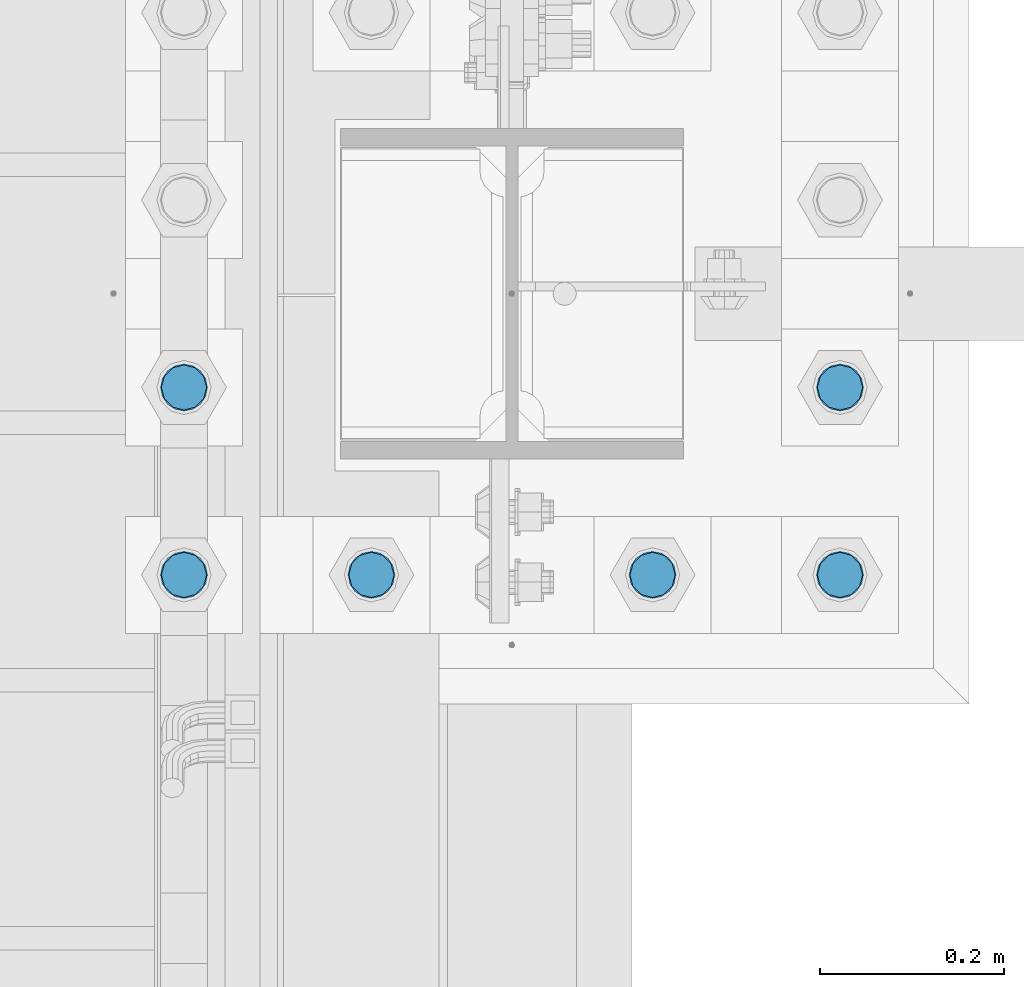
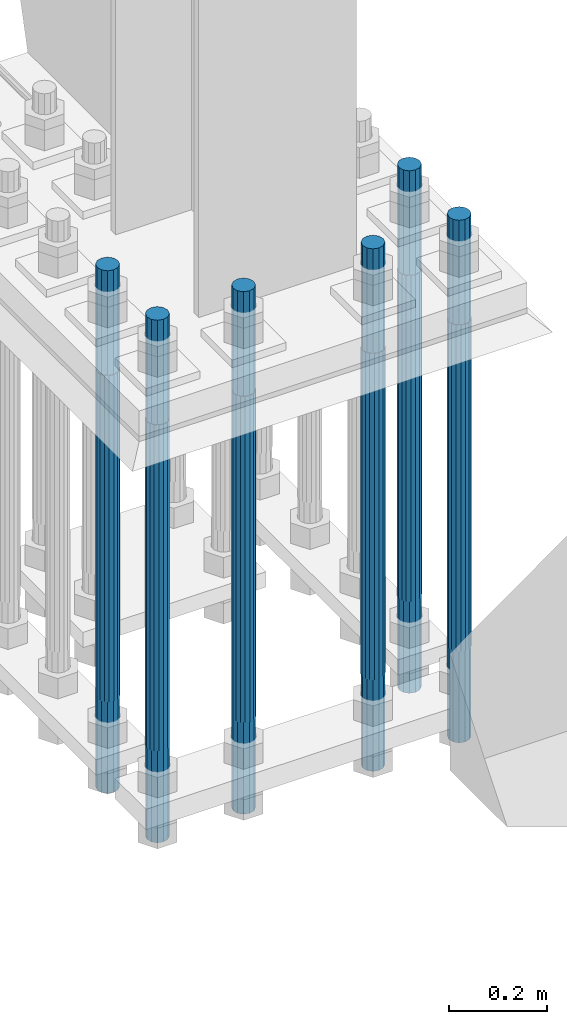
# One storey, part 1295 of 3843: 6 columns, 1 element without a shape of its own.
"""IFC2X3 building model written with IfcOpenShell, lengths in millimetres."""

from ifc_helpers import new_model, si_unit, frame, origin_with_axes, place, context, subcontext, project, spatial, faceted_brep, material, type_object, element, aggregate, save


model = new_model("IFC2X3")

# Units and contexts
model_context = context("Model", 3, precision=1e-05, world=origin_with_axes())
body_context = subcontext(model_context, "Body", "Model", "MODEL_VIEW")
ifc_project = project(units=[si_unit("LENGTHUNIT", "METRE", prefix="MILLI"), si_unit("AREAUNIT", "SQUARE_METRE"), si_unit("VOLUMEUNIT", "CUBIC_METRE"), si_unit("MASSUNIT", "GRAM", prefix="KILO"), si_unit("TIMEUNIT", "SECOND"), si_unit("PLANEANGLEUNIT", "RADIAN"), si_unit("SOLIDANGLEUNIT", "STERADIAN"), si_unit("THERMODYNAMICTEMPERATUREUNIT", "DEGREE_CELSIUS"), si_unit("LUMINOUSINTENSITYUNIT", "LUMEN")], contexts=[model_context])

# Site, building, storey
site_placement = place(None, origin_with_axes())
site = spatial("IfcSite", under=ifc_project, at=site_placement, CompositionType="ELEMENT")
building_placement = place(site_placement, origin_with_axes())
building = spatial("IfcBuilding", under=site, at=building_placement, Name="Undefined", CompositionType="ELEMENT")
storey_placement = place(building_placement, origin_with_axes())
storey = spatial("IfcBuildingStorey", under=building, at=storey_placement, Name="Undefined", CompositionType="ELEMENT", Elevation=0.0)

# Assembly, columns
assembly_placement = place(storey_placement, origin_with_axes())
assembly = element("IfcElementAssembly", 1, at=assembly_placement, inside=storey, Name="TEMPLATE", AssemblyPlace="NOTDEFINED", PredefinedType="RIGID_FRAME")
ifc_material = material(Name="Undefined/F1554-GR.55")
column_type = type_object("IfcColumnType", PredefinedType="NOTDEFINED")
column_1_placement = place(assembly_placement, frame((55575.2, 20002.5, 29565.6), z_axis=(0.0, -1.0, 0.0), x_axis=(0.0, 0.0, -1.0)))
column_1 = element("IfcColumn", 2, at=column_1_placement, type_object=column_type, material=ifc_material, Name="ANCHOR_ROD", context=body_context, shape_type="Brep", body=[
    faceted_brep([(-260.349999999999, -21.2176223927163, 12.25), (-260.349999999999, -12.25, 21.2176223927199), (-260.349999999999, 0.0, 24.5), (-260.349999999999, 12.25, 21.2176223927199), (-260.349999999999, 21.2176223927163, 12.25), (-260.349999999999, 24.5, 0.0), (-260.349999999999, 21.2176223927163, -12.25), (-260.349999999999, 12.25, -21.2176223927199), (-260.349999999999, 0.0, -24.5), (-260.349999999999, -12.25, -21.2176223927199), (-260.349999999999, -21.2176223927163, -12.25), (-260.349999999999, -24.5, 0.0), (0.0, 24.5000000000146, 0.0), (0.0, 21.2176223927381, -12.25), (0.0, 12.2500000000146, -21.2176223927163), (0.0, 1.45519152283669e-11, -24.5), (0.0, -12.2499999999854, -21.2176223927163), (0.0, -21.217622392709, -12.25), (0.0, -24.4999999999854, 0.0), (0.0, -21.217622392709, 12.25), (0.0, -12.2499999999854, 21.2176223927163), (0.0, 1.45519152283669e-11, 24.5), (0.0, 12.2500000000146, 21.2176223927163), (0.0, 21.2176223927381, 12.25), (0.0, -23.4665401257807, 9.72015918207035), (0.0, -17.9605122421344, 17.9605122421417), (0.0, -9.72015918207762, 23.466540125788), (0.0, 0.0, 25.4000000000015), (0.0, 9.72015918207762, 23.466540125788), (0.0, 17.9605122421344, 17.9605122421417), (0.0, 23.4665401257807, 9.72015918207035), (0.0, 25.3999996185303, 0.0), (0.0, 23.4665401257807, -9.72015918207035), (0.0, 17.9605122421344, -17.9605122421417), (0.0, 9.72015918207762, -23.466540125788), (0.0, 0.0, -25.4000000000015), (0.0, -9.72015918207762, -23.466540125788), (0.0, -17.9605122421344, -17.9605122421417), (0.0, -23.4665401257807, -9.72015918207035), (0.0, -25.3999996185303, 0.0), (812.799999999999, -25.4000000000015, 0.0), (812.799999999999, -23.466540125788, 9.72015918207398), (812.799999999999, -17.9605122421417, 17.9605122421381), (812.799999999999, -9.72015918207035, 23.466540125788), (812.799999999999, 0.0, 25.4000000000015), (812.799999999999, 9.72015918207035, 23.466540125788), (812.799999999999, 17.9605122421417, 17.9605122421381), (812.799999999999, 23.466540125788, 9.72015918207398), (812.799999999999, 25.4000000000015, 0.0), (812.799999999999, 23.466540125788, -9.72015918207398), (812.799999999999, 17.9605122421417, -17.9605122421381), (812.799999999999, 9.72015918207035, -23.466540125788), (812.799999999999, 0.0, -25.4000000000015), (812.799999999999, -9.72015918207035, -23.466540125788), (812.799999999999, -17.9605122421417, -17.9605122421381), (812.799999999999, -23.466540125788, -9.72015918207398), (812.799999999999, -12.25, 21.2176223927199), (812.799999999999, 0.0, 24.5), (812.799999999999, 12.25, 21.2176223927199), (812.799999999999, 21.2176223927163, 12.25), (812.799999999999, 24.5, 0.0), (812.799999999999, 21.2176223927163, -12.25), (812.799999999999, 12.25, -21.2176223927199), (812.799999999999, 0.0, -24.5), (812.799999999999, -12.25, -21.2176223927199), (812.799999999999, -21.2176223927163, -12.25), (812.799999999999, -24.5, 0.0), (812.799999999999, -21.2176223927163, 12.25), (1041.4, -12.25, -21.2176223927199), (1041.4, 0.0, -24.5), (1041.4, 12.25, -21.2176223927199), (1041.4, 21.2176223927163, -12.25), (1041.4, 24.5, 0.0), (1041.4, 21.2176223927163, 12.25), (1041.4, 12.25, 21.2176223927199), (1041.4, 0.0, 24.5), (1041.4, -12.25, 21.2176223927199), (1041.4, -21.2176223927163, 12.25), (1041.4, -24.5, 0.0), (1041.4, -21.2176223927163, -12.25)], [[[0, 1, 2, 3, 4, 5, 6, 7, 8, 9, 10, 11]], [[6, 5, 12, 13]], [[7, 6, 13, 14]], [[8, 7, 14, 15]], [[9, 8, 15, 16]], [[10, 9, 16, 17]], [[11, 10, 17, 18]], [[0, 11, 18, 19]], [[1, 0, 19, 20]], [[2, 1, 20, 21]], [[3, 2, 21, 22]], [[4, 3, 22, 23]], [[5, 4, 23, 12]], [[24, 25, 26, 27, 28, 29, 30, 31, 32, 33, 34, 35, 36, 37, 38, 39], [22, 21, 20, 19, 18, 17, 16, 15, 14, 13, 12, 23]], [[24, 39, 40, 41]], [[25, 24, 41, 42]], [[26, 25, 42, 43]], [[27, 26, 43, 44]], [[28, 27, 44, 45]], [[29, 28, 45, 46]], [[30, 29, 46, 47]], [[31, 30, 47, 48]], [[32, 31, 48, 49]], [[33, 32, 49, 50]], [[34, 33, 50, 51]], [[35, 34, 51, 52]], [[36, 35, 52, 53]], [[37, 36, 53, 54]], [[38, 37, 54, 55]], [[39, 38, 55, 40]], [[54, 53, 52, 51, 50, 49, 48, 47, 46, 45, 44, 43, 42, 41, 40, 55], [56, 57, 58, 59, 60, 61, 62, 63, 64, 65, 66, 67]], [[68, 69, 70, 71, 72, 73, 74, 75, 76, 77, 78, 79]], [[76, 75, 57, 56]], [[77, 76, 56, 67]], [[78, 77, 67, 66]], [[79, 78, 66, 65]], [[68, 79, 65, 64]], [[69, 68, 64, 63]], [[70, 69, 63, 62]], [[71, 70, 62, 61]], [[72, 71, 61, 60]], [[73, 72, 60, 59]], [[74, 73, 59, 58]], [[75, 74, 58, 57]]]),
])
column_2_placement = place(assembly_placement, frame((55778.4, 20002.5, 29565.6), z_axis=(0.0, -1.0, 0.0), x_axis=(0.0, 0.0, -1.0)))
column_2 = element("IfcColumn", 3, at=column_2_placement, type_object=column_type, material=ifc_material, Name="ANCHOR_ROD", context=body_context, shape_type="Brep", body=[
    faceted_brep([(-260.349999999999, -21.2176223927163, 12.25), (-260.349999999999, -12.25, 21.2176223927199), (-260.349999999999, 0.0, 24.5), (-260.349999999999, 12.25, 21.2176223927199), (-260.349999999999, 21.2176223927163, 12.25), (-260.349999999999, 24.5, 0.0), (-260.349999999999, 21.2176223927163, -12.25), (-260.349999999999, 12.25, -21.2176223927199), (-260.349999999999, 0.0, -24.5), (-260.349999999999, -12.25, -21.2176223927199), (-260.349999999999, -21.2176223927163, -12.25), (-260.349999999999, -24.5, 0.0), (0.0, 24.5000000000146, 0.0), (0.0, 21.2176223927381, -12.25), (0.0, 12.2500000000146, -21.2176223927163), (0.0, 1.45519152283669e-11, -24.5), (0.0, -12.2499999999854, -21.2176223927163), (0.0, -21.217622392709, -12.25), (0.0, -24.4999999999854, 0.0), (0.0, -21.217622392709, 12.25), (0.0, -12.2499999999854, 21.2176223927163), (0.0, 1.45519152283669e-11, 24.5), (0.0, 12.2500000000146, 21.2176223927163), (0.0, 21.2176223927381, 12.25), (0.0, -23.4665401257807, 9.72015918207035), (0.0, -17.9605122421344, 17.9605122421417), (0.0, -9.72015918207762, 23.466540125788), (0.0, 0.0, 25.4000000000015), (0.0, 9.72015918207762, 23.466540125788), (0.0, 17.9605122421344, 17.9605122421417), (0.0, 23.4665401257807, 9.72015918207035), (0.0, 25.3999996185303, 0.0), (0.0, 23.4665401257807, -9.72015918207035), (0.0, 17.9605122421344, -17.9605122421417), (0.0, 9.72015918207762, -23.466540125788), (0.0, 0.0, -25.4000000000015), (0.0, -9.72015918207762, -23.466540125788), (0.0, -17.9605122421344, -17.9605122421417), (0.0, -23.4665401257807, -9.72015918207035), (0.0, -25.3999996185303, 0.0), (812.799999999999, -25.4000000000015, 0.0), (812.799999999999, -23.466540125788, 9.72015918207398), (812.799999999999, -17.9605122421417, 17.9605122421381), (812.799999999999, -9.72015918207035, 23.466540125788), (812.799999999999, 0.0, 25.4000000000015), (812.799999999999, 9.72015918207035, 23.466540125788), (812.799999999999, 17.9605122421417, 17.9605122421381), (812.799999999999, 23.466540125788, 9.72015918207398), (812.799999999999, 25.4000000000015, 0.0), (812.799999999999, 23.466540125788, -9.72015918207398), (812.799999999999, 17.9605122421417, -17.9605122421381), (812.799999999999, 9.72015918207035, -23.466540125788), (812.799999999999, 0.0, -25.4000000000015), (812.799999999999, -9.72015918207035, -23.466540125788), (812.799999999999, -17.9605122421417, -17.9605122421381), (812.799999999999, -23.466540125788, -9.72015918207398), (812.799999999999, -12.25, 21.2176223927199), (812.799999999999, 0.0, 24.5), (812.799999999999, 12.25, 21.2176223927199), (812.799999999999, 21.2176223927163, 12.25), (812.799999999999, 24.5, 0.0), (812.799999999999, 21.2176223927163, -12.25), (812.799999999999, 12.25, -21.2176223927199), (812.799999999999, 0.0, -24.5), (812.799999999999, -12.25, -21.2176223927199), (812.799999999999, -21.2176223927163, -12.25), (812.799999999999, -24.5, 0.0), (812.799999999999, -21.2176223927163, 12.25), (1041.4, -12.25, -21.2176223927199), (1041.4, 0.0, -24.5), (1041.4, 12.25, -21.2176223927199), (1041.4, 21.2176223927163, -12.25), (1041.4, 24.5, 0.0), (1041.4, 21.2176223927163, 12.25), (1041.4, 12.25, 21.2176223927199), (1041.4, 0.0, 24.5), (1041.4, -12.25, 21.2176223927199), (1041.4, -21.2176223927163, 12.25), (1041.4, -24.5, 0.0), (1041.4, -21.2176223927163, -12.25)], [[[0, 1, 2, 3, 4, 5, 6, 7, 8, 9, 10, 11]], [[6, 5, 12, 13]], [[7, 6, 13, 14]], [[8, 7, 14, 15]], [[9, 8, 15, 16]], [[10, 9, 16, 17]], [[11, 10, 17, 18]], [[0, 11, 18, 19]], [[1, 0, 19, 20]], [[2, 1, 20, 21]], [[3, 2, 21, 22]], [[4, 3, 22, 23]], [[5, 4, 23, 12]], [[24, 25, 26, 27, 28, 29, 30, 31, 32, 33, 34, 35, 36, 37, 38, 39], [22, 21, 20, 19, 18, 17, 16, 15, 14, 13, 12, 23]], [[24, 39, 40, 41]], [[25, 24, 41, 42]], [[26, 25, 42, 43]], [[27, 26, 43, 44]], [[28, 27, 44, 45]], [[29, 28, 45, 46]], [[30, 29, 46, 47]], [[31, 30, 47, 48]], [[32, 31, 48, 49]], [[33, 32, 49, 50]], [[34, 33, 50, 51]], [[35, 34, 51, 52]], [[36, 35, 52, 53]], [[37, 36, 53, 54]], [[38, 37, 54, 55]], [[39, 38, 55, 40]], [[54, 53, 52, 51, 50, 49, 48, 47, 46, 45, 44, 43, 42, 41, 40, 55], [56, 57, 58, 59, 60, 61, 62, 63, 64, 65, 66, 67]], [[68, 69, 70, 71, 72, 73, 74, 75, 76, 77, 78, 79]], [[76, 75, 57, 56]], [[77, 76, 56, 67]], [[78, 77, 67, 66]], [[79, 78, 66, 65]], [[68, 79, 65, 64]], [[69, 68, 64, 63]], [[70, 69, 63, 62]], [[71, 70, 62, 61]], [[72, 71, 61, 60]], [[73, 72, 60, 59]], [[74, 73, 59, 58]], [[75, 74, 58, 57]]]),
])
column_3_placement = place(assembly_placement, frame((56083.2, 20002.5, 29565.6), z_axis=(0.0, 1.0, 0.0), x_axis=(0.0, 0.0, -1.0)))
column_3 = element("IfcColumn", 4, at=column_3_placement, type_object=column_type, material=ifc_material, Name="ANCHOR_ROD", context=body_context, shape_type="Brep", body=[
    faceted_brep([(-260.349999999999, -21.2176223927163, 12.25), (-260.349999999999, -12.25, 21.2176223927199), (-260.349999999999, 0.0, 24.5), (-260.349999999999, 12.25, 21.2176223927199), (-260.349999999999, 21.2176223927163, 12.25), (-260.349999999999, 24.5, 0.0), (-260.349999999999, 21.2176223927163, -12.25), (-260.349999999999, 12.25, -21.2176223927199), (-260.349999999999, 0.0, -24.5), (-260.349999999999, -12.25, -21.2176223927199), (-260.349999999999, -21.2176223927163, -12.25), (-260.349999999999, -24.5, 0.0), (0.0, 24.5000000000146, 0.0), (0.0, 21.2176223927381, -12.25), (0.0, 12.2500000000146, -21.2176223927163), (0.0, 1.45519152283669e-11, -24.5), (0.0, -12.2499999999854, -21.2176223927163), (0.0, -21.217622392709, -12.25), (0.0, -24.4999999999854, 0.0), (0.0, -21.217622392709, 12.25), (0.0, -12.2499999999854, 21.2176223927163), (0.0, 1.45519152283669e-11, 24.5), (0.0, 12.2500000000146, 21.2176223927163), (0.0, 21.2176223927381, 12.25), (0.0, -23.4665401257807, 9.72015918207035), (0.0, -17.9605122421344, 17.9605122421417), (0.0, -9.72015918207762, 23.466540125788), (0.0, 0.0, 25.4000000000015), (0.0, 9.72015918207762, 23.466540125788), (0.0, 17.9605122421344, 17.9605122421417), (0.0, 23.4665401257807, 9.72015918207035), (0.0, 25.3999996185303, 0.0), (0.0, 23.4665401257807, -9.72015918207035), (0.0, 17.9605122421344, -17.9605122421417), (0.0, 9.72015918207762, -23.466540125788), (0.0, 0.0, -25.4000000000015), (0.0, -9.72015918207762, -23.466540125788), (0.0, -17.9605122421344, -17.9605122421417), (0.0, -23.4665401257807, -9.72015918207035), (0.0, -25.3999996185303, 0.0), (812.799999999999, -25.4000000000015, 0.0), (812.799999999999, -23.466540125788, 9.72015918207398), (812.799999999999, -17.9605122421417, 17.9605122421381), (812.799999999999, -9.72015918207035, 23.466540125788), (812.799999999999, 0.0, 25.4000000000015), (812.799999999999, 9.72015918207035, 23.466540125788), (812.799999999999, 17.9605122421417, 17.9605122421381), (812.799999999999, 23.466540125788, 9.72015918207398), (812.799999999999, 25.4000000000015, 0.0), (812.799999999999, 23.466540125788, -9.72015918207398), (812.799999999999, 17.9605122421417, -17.9605122421381), (812.799999999999, 9.72015918207035, -23.466540125788), (812.799999999999, 0.0, -25.4000000000015), (812.799999999999, -9.72015918207035, -23.466540125788), (812.799999999999, -17.9605122421417, -17.9605122421381), (812.799999999999, -23.466540125788, -9.72015918207398), (812.799999999999, -12.25, 21.2176223927199), (812.799999999999, 0.0, 24.5), (812.799999999999, 12.25, 21.2176223927199), (812.799999999999, 21.2176223927163, 12.25), (812.799999999999, 24.5, 0.0), (812.799999999999, 21.2176223927163, -12.25), (812.799999999999, 12.25, -21.2176223927199), (812.799999999999, 0.0, -24.5), (812.799999999999, -12.25, -21.2176223927199), (812.799999999999, -21.2176223927163, -12.25), (812.799999999999, -24.5, 0.0), (812.799999999999, -21.2176223927163, 12.25), (1041.4, -12.25, -21.2176223927199), (1041.4, 0.0, -24.5), (1041.4, 12.25, -21.2176223927199), (1041.4, 21.2176223927163, -12.25), (1041.4, 24.5, 0.0), (1041.4, 21.2176223927163, 12.25), (1041.4, 12.25, 21.2176223927199), (1041.4, 0.0, 24.5), (1041.4, -12.25, 21.2176223927199), (1041.4, -21.2176223927163, 12.25), (1041.4, -24.5, 0.0), (1041.4, -21.2176223927163, -12.25)], [[[0, 1, 2, 3, 4, 5, 6, 7, 8, 9, 10, 11]], [[6, 5, 12, 13]], [[7, 6, 13, 14]], [[8, 7, 14, 15]], [[9, 8, 15, 16]], [[10, 9, 16, 17]], [[11, 10, 17, 18]], [[0, 11, 18, 19]], [[1, 0, 19, 20]], [[2, 1, 20, 21]], [[3, 2, 21, 22]], [[4, 3, 22, 23]], [[5, 4, 23, 12]], [[24, 25, 26, 27, 28, 29, 30, 31, 32, 33, 34, 35, 36, 37, 38, 39], [22, 21, 20, 19, 18, 17, 16, 15, 14, 13, 12, 23]], [[24, 39, 40, 41]], [[25, 24, 41, 42]], [[26, 25, 42, 43]], [[27, 26, 43, 44]], [[28, 27, 44, 45]], [[29, 28, 45, 46]], [[30, 29, 46, 47]], [[31, 30, 47, 48]], [[32, 31, 48, 49]], [[33, 32, 49, 50]], [[34, 33, 50, 51]], [[35, 34, 51, 52]], [[36, 35, 52, 53]], [[37, 36, 53, 54]], [[38, 37, 54, 55]], [[39, 38, 55, 40]], [[54, 53, 52, 51, 50, 49, 48, 47, 46, 45, 44, 43, 42, 41, 40, 55], [56, 57, 58, 59, 60, 61, 62, 63, 64, 65, 66, 67]], [[68, 69, 70, 71, 72, 73, 74, 75, 76, 77, 78, 79]], [[76, 75, 57, 56]], [[77, 76, 56, 67]], [[78, 77, 67, 66]], [[79, 78, 66, 65]], [[68, 79, 65, 64]], [[69, 68, 64, 63]], [[70, 69, 63, 62]], [[71, 70, 62, 61]], [[72, 71, 61, 60]], [[73, 72, 60, 59]], [[74, 73, 59, 58]], [[75, 74, 58, 57]]]),
])
column_4_placement = place(assembly_placement, frame((56286.4, 20002.5, 29565.6), z_axis=(0.0, 1.0, 0.0), x_axis=(0.0, 0.0, -1.0)))
column_4 = element("IfcColumn", 5, at=column_4_placement, type_object=column_type, material=ifc_material, Name="ANCHOR_ROD", context=body_context, shape_type="Brep", body=[
    faceted_brep([(-260.349999999999, -21.2176223927163, 12.25), (-260.349999999999, -12.25, 21.2176223927199), (-260.349999999999, 0.0, 24.5), (-260.349999999999, 12.25, 21.2176223927199), (-260.349999999999, 21.2176223927163, 12.25), (-260.349999999999, 24.5, 0.0), (-260.349999999999, 21.2176223927163, -12.25), (-260.349999999999, 12.25, -21.2176223927199), (-260.349999999999, 0.0, -24.5), (-260.349999999999, -12.25, -21.2176223927199), (-260.349999999999, -21.2176223927163, -12.25), (-260.349999999999, -24.5, 0.0), (0.0, 24.5000000000146, 0.0), (0.0, 21.2176223927381, -12.25), (0.0, 12.2500000000146, -21.2176223927163), (0.0, 1.45519152283669e-11, -24.5), (0.0, -12.2499999999854, -21.2176223927163), (0.0, -21.217622392709, -12.25), (0.0, -24.4999999999854, 0.0), (0.0, -21.217622392709, 12.25), (0.0, -12.2499999999854, 21.2176223927163), (0.0, 1.45519152283669e-11, 24.5), (0.0, 12.2500000000146, 21.2176223927163), (0.0, 21.2176223927381, 12.25), (0.0, -23.4665401257807, 9.72015918207035), (0.0, -17.9605122421344, 17.9605122421417), (0.0, -9.72015918207762, 23.466540125788), (0.0, 0.0, 25.4000000000015), (0.0, 9.72015918207762, 23.466540125788), (0.0, 17.9605122421344, 17.9605122421417), (0.0, 23.4665401257807, 9.72015918207035), (0.0, 25.3999996185303, 0.0), (0.0, 23.4665401257807, -9.72015918207035), (0.0, 17.9605122421344, -17.9605122421417), (0.0, 9.72015918207762, -23.466540125788), (0.0, 0.0, -25.4000000000015), (0.0, -9.72015918207762, -23.466540125788), (0.0, -17.9605122421344, -17.9605122421417), (0.0, -23.4665401257807, -9.72015918207035), (0.0, -25.3999996185303, 0.0), (812.799999999999, -25.4000000000015, 0.0), (812.799999999999, -23.466540125788, 9.72015918207398), (812.799999999999, -17.9605122421417, 17.9605122421381), (812.799999999999, -9.72015918207035, 23.466540125788), (812.799999999999, 0.0, 25.4000000000015), (812.799999999999, 9.72015918207035, 23.466540125788), (812.799999999999, 17.9605122421417, 17.9605122421381), (812.799999999999, 23.466540125788, 9.72015918207398), (812.799999999999, 25.4000000000015, 0.0), (812.799999999999, 23.466540125788, -9.72015918207398), (812.799999999999, 17.9605122421417, -17.9605122421381), (812.799999999999, 9.72015918207035, -23.466540125788), (812.799999999999, 0.0, -25.4000000000015), (812.799999999999, -9.72015918207035, -23.466540125788), (812.799999999999, -17.9605122421417, -17.9605122421381), (812.799999999999, -23.466540125788, -9.72015918207398), (812.799999999999, -12.25, 21.2176223927199), (812.799999999999, 0.0, 24.5), (812.799999999999, 12.25, 21.2176223927199), (812.799999999999, 21.2176223927163, 12.25), (812.799999999999, 24.5, 0.0), (812.799999999999, 21.2176223927163, -12.25), (812.799999999999, 12.25, -21.2176223927199), (812.799999999999, 0.0, -24.5), (812.799999999999, -12.25, -21.2176223927199), (812.799999999999, -21.2176223927163, -12.25), (812.799999999999, -24.5, 0.0), (812.799999999999, -21.2176223927163, 12.25), (1041.4, -12.25, -21.2176223927199), (1041.4, 0.0, -24.5), (1041.4, 12.25, -21.2176223927199), (1041.4, 21.2176223927163, -12.25), (1041.4, 24.5, 0.0), (1041.4, 21.2176223927163, 12.25), (1041.4, 12.25, 21.2176223927199), (1041.4, 0.0, 24.5), (1041.4, -12.25, 21.2176223927199), (1041.4, -21.2176223927163, 12.25), (1041.4, -24.5, 0.0), (1041.4, -21.2176223927163, -12.25)], [[[0, 1, 2, 3, 4, 5, 6, 7, 8, 9, 10, 11]], [[6, 5, 12, 13]], [[7, 6, 13, 14]], [[8, 7, 14, 15]], [[9, 8, 15, 16]], [[10, 9, 16, 17]], [[11, 10, 17, 18]], [[0, 11, 18, 19]], [[1, 0, 19, 20]], [[2, 1, 20, 21]], [[3, 2, 21, 22]], [[4, 3, 22, 23]], [[5, 4, 23, 12]], [[24, 25, 26, 27, 28, 29, 30, 31, 32, 33, 34, 35, 36, 37, 38, 39], [22, 21, 20, 19, 18, 17, 16, 15, 14, 13, 12, 23]], [[24, 39, 40, 41]], [[25, 24, 41, 42]], [[26, 25, 42, 43]], [[27, 26, 43, 44]], [[28, 27, 44, 45]], [[29, 28, 45, 46]], [[30, 29, 46, 47]], [[31, 30, 47, 48]], [[32, 31, 48, 49]], [[33, 32, 49, 50]], [[34, 33, 50, 51]], [[35, 34, 51, 52]], [[36, 35, 52, 53]], [[37, 36, 53, 54]], [[38, 37, 54, 55]], [[39, 38, 55, 40]], [[54, 53, 52, 51, 50, 49, 48, 47, 46, 45, 44, 43, 42, 41, 40, 55], [56, 57, 58, 59, 60, 61, 62, 63, 64, 65, 66, 67]], [[68, 69, 70, 71, 72, 73, 74, 75, 76, 77, 78, 79]], [[76, 75, 57, 56]], [[77, 76, 56, 67]], [[78, 77, 67, 66]], [[79, 78, 66, 65]], [[68, 79, 65, 64]], [[69, 68, 64, 63]], [[70, 69, 63, 62]], [[71, 70, 62, 61]], [[72, 71, 61, 60]], [[73, 72, 60, 59]], [[74, 73, 59, 58]], [[75, 74, 58, 57]]]),
])
column_5_placement = place(assembly_placement, frame((55575.2, 20205.7, 29565.6), z_axis=(0.0, -1.0, 0.0), x_axis=(0.0, 0.0, -1.0)))
column_5 = element("IfcColumn", 6, at=column_5_placement, type_object=column_type, material=ifc_material, Name="ANCHOR_ROD", context=body_context, shape_type="Brep", body=[
    faceted_brep([(-260.349999999999, -21.2176223927163, 12.25), (-260.349999999999, -12.25, 21.2176223927199), (-260.349999999999, 0.0, 24.5), (-260.349999999999, 12.25, 21.2176223927199), (-260.349999999999, 21.2176223927163, 12.25), (-260.349999999999, 24.5, 0.0), (-260.349999999999, 21.2176223927163, -12.25), (-260.349999999999, 12.25, -21.2176223927199), (-260.349999999999, 0.0, -24.5), (-260.349999999999, -12.25, -21.2176223927199), (-260.349999999999, -21.2176223927163, -12.25), (-260.349999999999, -24.5, 0.0), (0.0, 24.5000000000146, 0.0), (0.0, 21.2176223927381, -12.25), (0.0, 12.2500000000146, -21.2176223927163), (0.0, 1.45519152283669e-11, -24.5), (0.0, -12.2499999999854, -21.2176223927163), (0.0, -21.217622392709, -12.25), (0.0, -24.4999999999854, 0.0), (0.0, -21.217622392709, 12.25), (0.0, -12.2499999999854, 21.2176223927163), (0.0, 1.45519152283669e-11, 24.5), (0.0, 12.2500000000146, 21.2176223927163), (0.0, 21.2176223927381, 12.25), (0.0, -23.4665401257807, 9.72015918207035), (0.0, -17.9605122421344, 17.9605122421417), (0.0, -9.72015918207762, 23.466540125788), (0.0, 0.0, 25.4000000000015), (0.0, 9.72015918207762, 23.466540125788), (0.0, 17.9605122421344, 17.9605122421417), (0.0, 23.4665401257807, 9.72015918207035), (0.0, 25.3999996185303, 0.0), (0.0, 23.4665401257807, -9.72015918207035), (0.0, 17.9605122421344, -17.9605122421417), (0.0, 9.72015918207762, -23.466540125788), (0.0, 0.0, -25.4000000000015), (0.0, -9.72015918207762, -23.466540125788), (0.0, -17.9605122421344, -17.9605122421417), (0.0, -23.4665401257807, -9.72015918207035), (0.0, -25.3999996185303, 0.0), (812.799999999999, -25.4000000000015, 0.0), (812.799999999999, -23.466540125788, 9.72015918207398), (812.799999999999, -17.9605122421417, 17.9605122421381), (812.799999999999, -9.72015918207035, 23.466540125788), (812.799999999999, 0.0, 25.4000000000015), (812.799999999999, 9.72015918207035, 23.466540125788), (812.799999999999, 17.9605122421417, 17.9605122421381), (812.799999999999, 23.466540125788, 9.72015918207398), (812.799999999999, 25.4000000000015, 0.0), (812.799999999999, 23.466540125788, -9.72015918207398), (812.799999999999, 17.9605122421417, -17.9605122421381), (812.799999999999, 9.72015918207035, -23.466540125788), (812.799999999999, 0.0, -25.4000000000015), (812.799999999999, -9.72015918207035, -23.466540125788), (812.799999999999, -17.9605122421417, -17.9605122421381), (812.799999999999, -23.466540125788, -9.72015918207398), (812.799999999999, -12.25, 21.2176223927199), (812.799999999999, 0.0, 24.5), (812.799999999999, 12.25, 21.2176223927199), (812.799999999999, 21.2176223927163, 12.25), (812.799999999999, 24.5, 0.0), (812.799999999999, 21.2176223927163, -12.25), (812.799999999999, 12.25, -21.2176223927199), (812.799999999999, 0.0, -24.5), (812.799999999999, -12.25, -21.2176223927199), (812.799999999999, -21.2176223927163, -12.25), (812.799999999999, -24.5, 0.0), (812.799999999999, -21.2176223927163, 12.25), (1041.4, -12.25, -21.2176223927199), (1041.4, 0.0, -24.5), (1041.4, 12.25, -21.2176223927199), (1041.4, 21.2176223927163, -12.25), (1041.4, 24.5, 0.0), (1041.4, 21.2176223927163, 12.25), (1041.4, 12.25, 21.2176223927199), (1041.4, 0.0, 24.5), (1041.4, -12.25, 21.2176223927199), (1041.4, -21.2176223927163, 12.25), (1041.4, -24.5, 0.0), (1041.4, -21.2176223927163, -12.25)], [[[0, 1, 2, 3, 4, 5, 6, 7, 8, 9, 10, 11]], [[6, 5, 12, 13]], [[7, 6, 13, 14]], [[8, 7, 14, 15]], [[9, 8, 15, 16]], [[10, 9, 16, 17]], [[11, 10, 17, 18]], [[0, 11, 18, 19]], [[1, 0, 19, 20]], [[2, 1, 20, 21]], [[3, 2, 21, 22]], [[4, 3, 22, 23]], [[5, 4, 23, 12]], [[24, 25, 26, 27, 28, 29, 30, 31, 32, 33, 34, 35, 36, 37, 38, 39], [22, 21, 20, 19, 18, 17, 16, 15, 14, 13, 12, 23]], [[24, 39, 40, 41]], [[25, 24, 41, 42]], [[26, 25, 42, 43]], [[27, 26, 43, 44]], [[28, 27, 44, 45]], [[29, 28, 45, 46]], [[30, 29, 46, 47]], [[31, 30, 47, 48]], [[32, 31, 48, 49]], [[33, 32, 49, 50]], [[34, 33, 50, 51]], [[35, 34, 51, 52]], [[36, 35, 52, 53]], [[37, 36, 53, 54]], [[38, 37, 54, 55]], [[39, 38, 55, 40]], [[54, 53, 52, 51, 50, 49, 48, 47, 46, 45, 44, 43, 42, 41, 40, 55], [56, 57, 58, 59, 60, 61, 62, 63, 64, 65, 66, 67]], [[68, 69, 70, 71, 72, 73, 74, 75, 76, 77, 78, 79]], [[76, 75, 57, 56]], [[77, 76, 56, 67]], [[78, 77, 67, 66]], [[79, 78, 66, 65]], [[68, 79, 65, 64]], [[69, 68, 64, 63]], [[70, 69, 63, 62]], [[71, 70, 62, 61]], [[72, 71, 61, 60]], [[73, 72, 60, 59]], [[74, 73, 59, 58]], [[75, 74, 58, 57]]]),
])
column_6_placement = place(assembly_placement, frame((56286.4, 20205.7, 29565.6), z_axis=(0.0, 1.0, 0.0), x_axis=(0.0, 0.0, -1.0)))
column_6 = element("IfcColumn", 7, at=column_6_placement, type_object=column_type, material=ifc_material, Name="ANCHOR_ROD", context=body_context, shape_type="Brep", body=[
    faceted_brep([(-260.349999999999, -21.2176223927163, 12.25), (-260.349999999999, -12.25, 21.2176223927199), (-260.349999999999, 0.0, 24.5), (-260.349999999999, 12.25, 21.2176223927199), (-260.349999999999, 21.2176223927163, 12.25), (-260.349999999999, 24.5, 0.0), (-260.349999999999, 21.2176223927163, -12.25), (-260.349999999999, 12.25, -21.2176223927199), (-260.349999999999, 0.0, -24.5), (-260.349999999999, -12.25, -21.2176223927199), (-260.349999999999, -21.2176223927163, -12.25), (-260.349999999999, -24.5, 0.0), (0.0, 24.5000000000146, 0.0), (0.0, 21.2176223927381, -12.25), (0.0, 12.2500000000146, -21.2176223927163), (0.0, 1.45519152283669e-11, -24.5), (0.0, -12.2499999999854, -21.2176223927163), (0.0, -21.217622392709, -12.25), (0.0, -24.4999999999854, 0.0), (0.0, -21.217622392709, 12.25), (0.0, -12.2499999999854, 21.2176223927163), (0.0, 1.45519152283669e-11, 24.5), (0.0, 12.2500000000146, 21.2176223927163), (0.0, 21.2176223927381, 12.25), (0.0, -23.4665401257807, 9.72015918207035), (0.0, -17.9605122421344, 17.9605122421417), (0.0, -9.72015918207762, 23.466540125788), (0.0, 0.0, 25.4000000000015), (0.0, 9.72015918207762, 23.466540125788), (0.0, 17.9605122421344, 17.9605122421417), (0.0, 23.4665401257807, 9.72015918207035), (0.0, 25.3999996185303, 0.0), (0.0, 23.4665401257807, -9.72015918207035), (0.0, 17.9605122421344, -17.9605122421417), (0.0, 9.72015918207762, -23.466540125788), (0.0, 0.0, -25.4000000000015), (0.0, -9.72015918207762, -23.466540125788), (0.0, -17.9605122421344, -17.9605122421417), (0.0, -23.4665401257807, -9.72015918207035), (0.0, -25.3999996185303, 0.0), (812.799999999999, -25.4000000000015, 0.0), (812.799999999999, -23.466540125788, 9.72015918207398), (812.799999999999, -17.9605122421417, 17.9605122421381), (812.799999999999, -9.72015918207035, 23.466540125788), (812.799999999999, 0.0, 25.4000000000015), (812.799999999999, 9.72015918207035, 23.466540125788), (812.799999999999, 17.9605122421417, 17.9605122421381), (812.799999999999, 23.466540125788, 9.72015918207398), (812.799999999999, 25.4000000000015, 0.0), (812.799999999999, 23.466540125788, -9.72015918207398), (812.799999999999, 17.9605122421417, -17.9605122421381), (812.799999999999, 9.72015918207035, -23.466540125788), (812.799999999999, 0.0, -25.4000000000015), (812.799999999999, -9.72015918207035, -23.466540125788), (812.799999999999, -17.9605122421417, -17.9605122421381), (812.799999999999, -23.466540125788, -9.72015918207398), (812.799999999999, -12.25, 21.2176223927199), (812.799999999999, 0.0, 24.5), (812.799999999999, 12.25, 21.2176223927199), (812.799999999999, 21.2176223927163, 12.25), (812.799999999999, 24.5, 0.0), (812.799999999999, 21.2176223927163, -12.25), (812.799999999999, 12.25, -21.2176223927199), (812.799999999999, 0.0, -24.5), (812.799999999999, -12.25, -21.2176223927199), (812.799999999999, -21.2176223927163, -12.25), (812.799999999999, -24.5, 0.0), (812.799999999999, -21.2176223927163, 12.25), (1041.4, -12.25, -21.2176223927199), (1041.4, 0.0, -24.5), (1041.4, 12.25, -21.2176223927199), (1041.4, 21.2176223927163, -12.25), (1041.4, 24.5, 0.0), (1041.4, 21.2176223927163, 12.25), (1041.4, 12.25, 21.2176223927199), (1041.4, 0.0, 24.5), (1041.4, -12.25, 21.2176223927199), (1041.4, -21.2176223927163, 12.25), (1041.4, -24.5, 0.0), (1041.4, -21.2176223927163, -12.25)], [[[0, 1, 2, 3, 4, 5, 6, 7, 8, 9, 10, 11]], [[6, 5, 12, 13]], [[7, 6, 13, 14]], [[8, 7, 14, 15]], [[9, 8, 15, 16]], [[10, 9, 16, 17]], [[11, 10, 17, 18]], [[0, 11, 18, 19]], [[1, 0, 19, 20]], [[2, 1, 20, 21]], [[3, 2, 21, 22]], [[4, 3, 22, 23]], [[5, 4, 23, 12]], [[24, 25, 26, 27, 28, 29, 30, 31, 32, 33, 34, 35, 36, 37, 38, 39], [22, 21, 20, 19, 18, 17, 16, 15, 14, 13, 12, 23]], [[24, 39, 40, 41]], [[25, 24, 41, 42]], [[26, 25, 42, 43]], [[27, 26, 43, 44]], [[28, 27, 44, 45]], [[29, 28, 45, 46]], [[30, 29, 46, 47]], [[31, 30, 47, 48]], [[32, 31, 48, 49]], [[33, 32, 49, 50]], [[34, 33, 50, 51]], [[35, 34, 51, 52]], [[36, 35, 52, 53]], [[37, 36, 53, 54]], [[38, 37, 54, 55]], [[39, 38, 55, 40]], [[54, 53, 52, 51, 50, 49, 48, 47, 46, 45, 44, 43, 42, 41, 40, 55], [56, 57, 58, 59, 60, 61, 62, 63, 64, 65, 66, 67]], [[68, 69, 70, 71, 72, 73, 74, 75, 76, 77, 78, 79]], [[76, 75, 57, 56]], [[77, 76, 56, 67]], [[78, 77, 67, 66]], [[79, 78, 66, 65]], [[68, 79, 65, 64]], [[69, 68, 64, 63]], [[70, 69, 63, 62]], [[71, 70, 62, 61]], [[72, 71, 61, 60]], [[73, 72, 60, 59]], [[74, 73, 59, 58]], [[75, 74, 58, 57]]]),
])
aggregate(assembly, [column_1, column_2, column_3, column_4, column_5, column_6])

save(model, "model.ifc")
